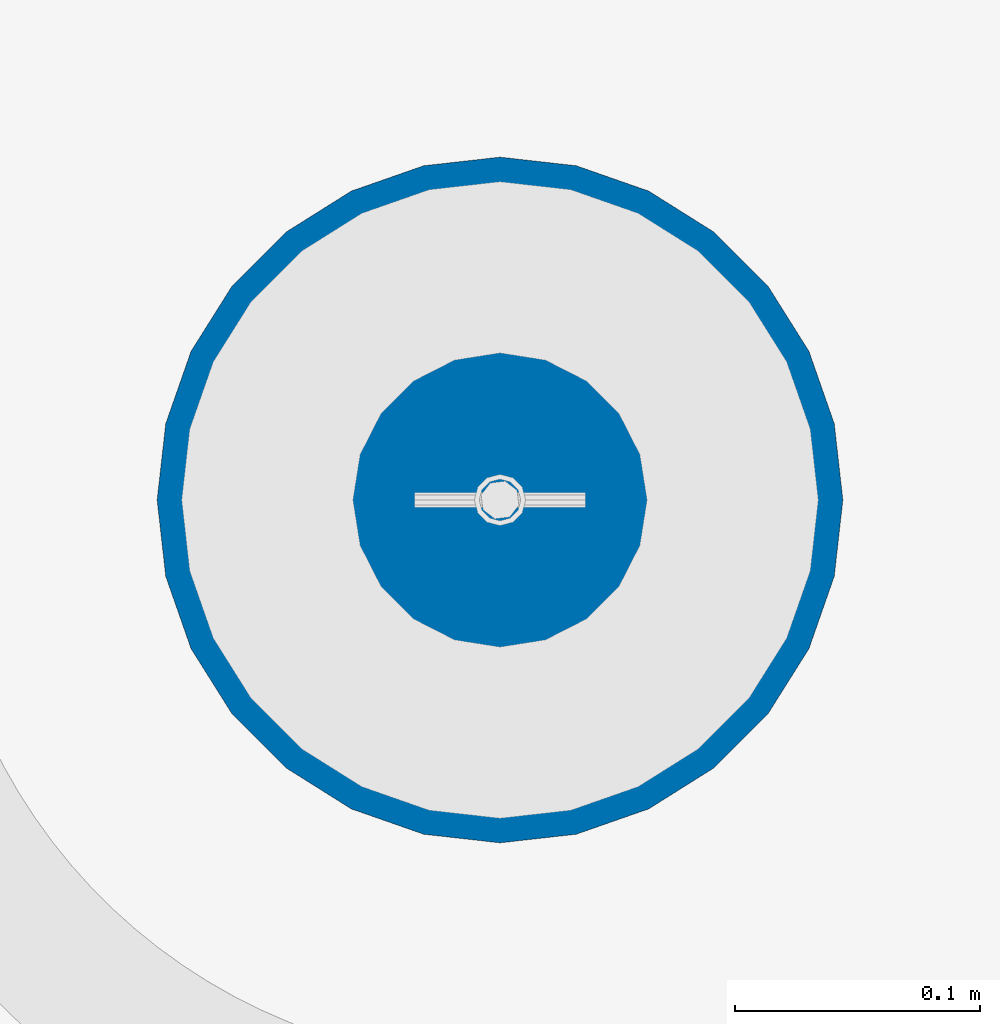
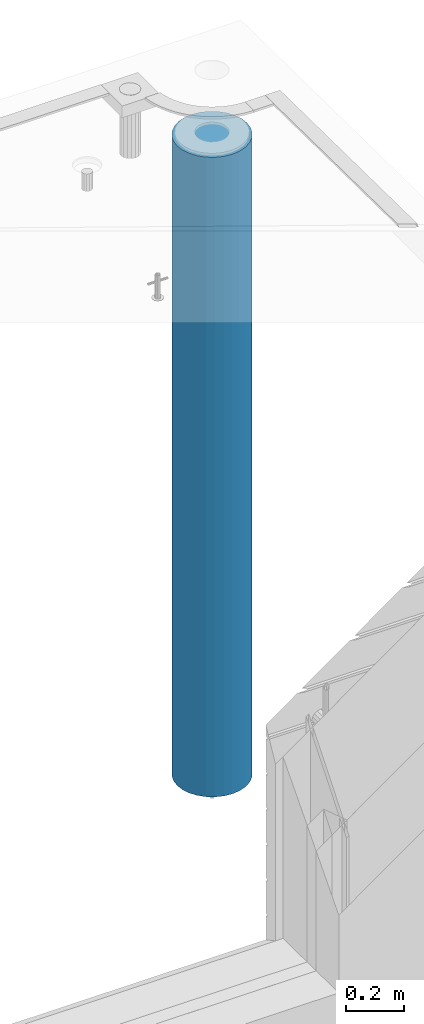
# One storey, part 6 of 334: 1 column, 1 element without a shape of its own.
"""IFC2X3 building model written with IfcOpenShell, lengths in millimetres."""

from ifc_helpers import new_model, si_unit, frame, origin_with_axes, place, context, subcontext, project, spatial, faceted_brep, material, type_object, element, aggregate, save


model = new_model("IFC2X3")

# Units and contexts
model_context = context("Model", 3, precision=1e-05, world=origin_with_axes())
body_context = subcontext(model_context, "Body", "Model", "MODEL_VIEW")
ifc_project = project(units=[si_unit("LENGTHUNIT", "METRE", prefix="MILLI"), si_unit("AREAUNIT", "SQUARE_METRE"), si_unit("VOLUMEUNIT", "CUBIC_METRE"), si_unit("MASSUNIT", "GRAM", prefix="KILO"), si_unit("TIMEUNIT", "SECOND"), si_unit("PLANEANGLEUNIT", "RADIAN"), si_unit("SOLIDANGLEUNIT", "STERADIAN"), si_unit("THERMODYNAMICTEMPERATUREUNIT", "DEGREE_CELSIUS"), si_unit("LUMINOUSINTENSITYUNIT", "LUMEN")], contexts=[model_context])

# Site, building, storey
site_placement = place(None, origin_with_axes())
site = spatial("IfcSite", under=ifc_project, at=site_placement, CompositionType="ELEMENT")
building_placement = place(site_placement, origin_with_axes())
building = spatial("IfcBuilding", under=site, at=building_placement, CompositionType="ELEMENT")
storey_placement = place(building_placement, origin_with_axes())
storey = spatial("IfcBuildingStorey", under=building, at=storey_placement, Name="3", CompositionType="ELEMENT", Elevation=0.0)

# Assembly, column
assembly_placement = place(storey_placement, origin_with_axes())
assembly = element("IfcElementAssembly", 1, at=assembly_placement, inside=storey, AssemblyPlace="NOTDEFINED", PredefinedType="REINFORCEMENT_UNIT")
ifc_material = material(Name="CONCRETE/C30/37")
column_type = type_object("IfcColumnType", Name="D280", PredefinedType="NOTDEFINED")
column_placement = place(assembly_placement, frame((35009.9987952044, 22669.984888838, 87725.0), z_axis=(-1.0, 3.00000001838171e-08, 0.0), x_axis=(0.0, 0.0, 1.0)))
column = element("IfcColumn", 2, at=column_placement, type_object=column_type, material=ifc_material, ObjectType="D280", context=body_context, shape_type="Brep", body=[
    faceted_brep([(0.0, -140.0, 0.0), (0.0, -136.489907705454, -31.1529307538876), (2710.0, -136.489907705454, -31.1529307538876), (2710.0, -140.0, 0.0), (0.0, -126.135641506338, -60.7437234764584), (2710.0, -126.135641506338, -60.7437234764584), (0.0, -109.456407545524, -87.2885722602223), (2710.0, -109.456407545524, -87.2885722602223), (0.0, -87.2885722602223, -109.456407545527), (2710.0, -87.2885722602223, -109.456407545527), (0.0, -60.7437234764584, -126.135641506342), (2710.0, -60.7437234764584, -126.135641506342), (0.0, -31.152930753884, -136.489907705458), (2710.0, -31.152930753884, -136.489907705458), (0.0, 0.0, -140.0), (2710.0, 0.0, -140.0), (0.0, 31.152930753884, -136.489907705458), (2710.0, 31.152930753884, -136.489907705458), (0.0, 60.7437234764584, -126.135641506342), (2710.0, 60.7437234764584, -126.135641506342), (0.0, 87.2885722602223, -109.456407545527), (2710.0, 87.2885722602223, -109.456407545527), (0.0, 109.456407545524, -87.2885722602223), (2710.0, 109.456407545524, -87.2885722602223), (0.0, 126.135641506338, -60.7437234764584), (2710.0, 126.135641506338, -60.7437234764584), (0.0, 136.489907705454, -31.1529307538876), (2710.0, 136.489907705454, -31.1529307538876), (0.0, 140.0, 0.0), (2710.0, 140.0, 0.0), (0.0, 136.489907705454, 31.1529307538876), (2710.0, 136.489907705454, 31.1529307538876), (0.0, 126.135641506338, 60.7437234764584), (2710.0, 126.135641506338, 60.7437234764584), (0.0, 109.456407545524, 87.2885722602223), (2710.0, 109.456407545524, 87.2885722602223), (0.0, 87.2885722602223, 109.456407545527), (2710.0, 87.2885722602223, 109.456407545527), (0.0, 60.7437234764584, 126.135641506342), (2710.0, 60.7437234764584, 126.135641506342), (0.0, 31.152930753884, 136.489907705458), (2710.0, 31.152930753884, 136.489907705458), (0.0, 0.0, 140.0), (2710.0, 0.0, 140.0), (0.0, -31.152930753884, 136.489907705458), (2710.0, -31.152930753884, 136.489907705458), (0.0, -60.7437234764584, 126.135641506342), (2710.0, -60.7437234764584, 126.135641506342), (0.0, -87.2885722602223, 109.456407545527), (2710.0, -87.2885722602223, 109.456407545527), (0.0, -109.456407545524, 87.2885722602223), (2710.0, -109.456407545524, 87.2885722602223), (0.0, -126.135641506338, 60.7437234764584), (2710.0, -126.135641506338, 60.7437234764584), (0.0, -136.489907705454, 31.1529307538876), (2710.0, -136.489907705454, 31.1529307538876)], [[[0, 1, 2, 3]], [[1, 4, 5, 2]], [[4, 6, 7, 5]], [[6, 8, 9, 7]], [[8, 10, 11, 9]], [[10, 12, 13, 11]], [[12, 14, 15, 13]], [[14, 16, 17, 15]], [[16, 18, 19, 17]], [[18, 20, 21, 19]], [[20, 22, 23, 21]], [[22, 24, 25, 23]], [[24, 26, 27, 25]], [[26, 28, 29, 27]], [[28, 30, 31, 29]], [[30, 32, 33, 31]], [[32, 34, 35, 33]], [[34, 36, 37, 35]], [[36, 38, 39, 37]], [[38, 40, 41, 39]], [[40, 42, 43, 41]], [[42, 44, 45, 43]], [[44, 46, 47, 45]], [[46, 48, 49, 47]], [[48, 50, 51, 49]], [[50, 52, 53, 51]], [[52, 54, 55, 53]], [[54, 0, 3, 55]], [[5, 7, 9, 11, 13, 15, 17, 19, 21, 23, 25, 27, 29, 31, 33, 35, 37, 39, 41, 43, 45, 47, 49, 51, 53, 55, 3, 2]], [[54, 52, 50, 48, 46, 44, 42, 40, 38, 36, 34, 32, 30, 28, 26, 24, 22, 20, 18, 16, 14, 12, 10, 8, 6, 4, 1, 0]]]),
])
aggregate(assembly, [column])

save(model, "model.ifc")
